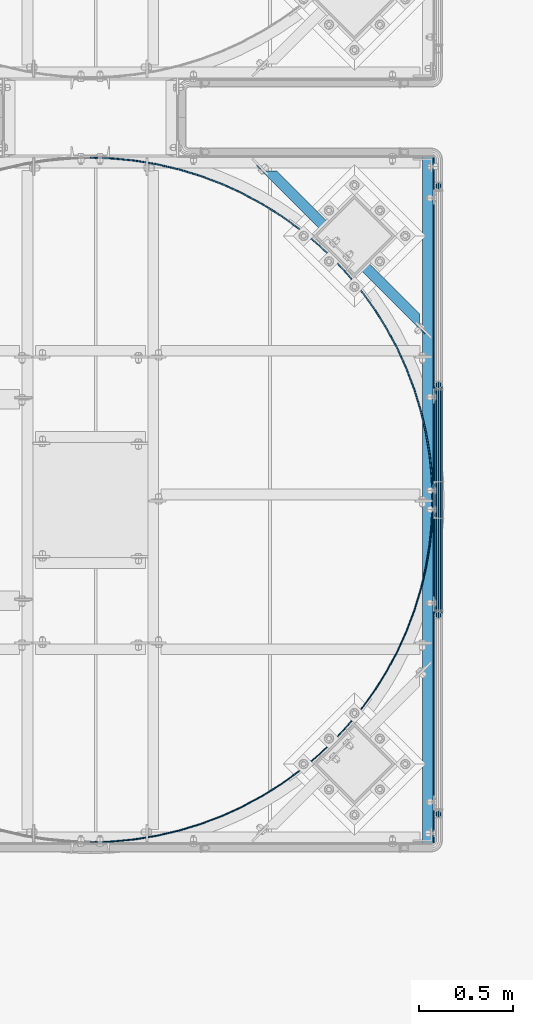
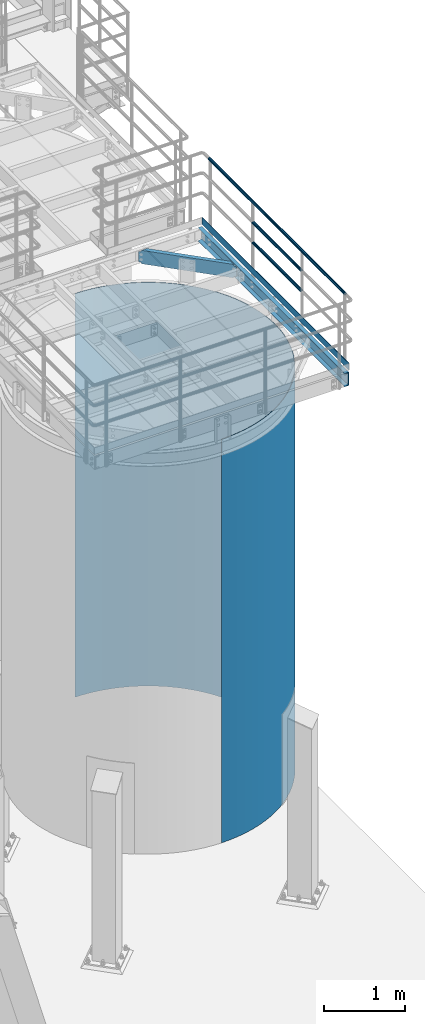
# One storey, part 924 of 1876: 7 beams, 4 elements without a shape of their own.
"""IFC2X3 building model written with IfcOpenShell, lengths in millimetres."""

from ifc_helpers import new_model, si_unit, frame, origin_with_axes, place, context, subcontext, project, spatial, faceted_brep, material, type_object, element, aggregate, save


model = new_model("IFC2X3")

# Units and contexts
model_context = context("Model", 3, precision=1e-05, world=origin_with_axes())
body_context = subcontext(model_context, "Body", "Model", "MODEL_VIEW")
ifc_project = project(units=[si_unit("LENGTHUNIT", "METRE", prefix="MILLI"), si_unit("AREAUNIT", "SQUARE_METRE"), si_unit("VOLUMEUNIT", "CUBIC_METRE"), si_unit("MASSUNIT", "GRAM", prefix="KILO"), si_unit("TIMEUNIT", "SECOND"), si_unit("PLANEANGLEUNIT", "RADIAN"), si_unit("SOLIDANGLEUNIT", "STERADIAN"), si_unit("THERMODYNAMICTEMPERATUREUNIT", "DEGREE_CELSIUS"), si_unit("LUMINOUSINTENSITYUNIT", "LUMEN")], contexts=[model_context])

# Site, building, storey
site_placement = place(None, origin_with_axes())
site = spatial("IfcSite", under=ifc_project, at=site_placement, CompositionType="ELEMENT")
building_placement = place(site_placement, origin_with_axes())
building = spatial("IfcBuilding", under=site, at=building_placement, Name="Undefined", CompositionType="ELEMENT")
storey_placement = place(building_placement, origin_with_axes())
storey = spatial("IfcBuildingStorey", under=building, at=storey_placement, Name="Undefined", CompositionType="ELEMENT", Elevation=0.0)

# Assembly, beams
assembly_1_placement = place(storey_placement, origin_with_axes())
assembly_1 = element("IfcElementAssembly", 1, at=assembly_1_placement, inside=storey, Name="HANDRAIL", AssemblyPlace="NOTDEFINED", PredefinedType="RIGID_FRAME")
ifc_material_1 = material()
beam_type_1 = type_object("IfcBeamType", Name="PIPE1-1/4STD", PredefinedType="NOTDEFINED")
beam_1_placement = place(assembly_1_placement, frame((7025.13056849878, -14198.5644042969, 8480.425), z_axis=(0.0, 0.0, 1.0), x_axis=(0.0, 1.0, 0.0)))
beam_1 = element("IfcBeam", 2, at=beam_1_placement, type_object=beam_type_1, material=ifc_material_1, Name="RAIL", ObjectType="PIPE1-1/4STD", context=body_context, shape_type="Brep", body=[
    faceted_brep([(1200.94245243742, -10.5409999999993, 18.2575475625836), (1200.94245243742, -10.5409999999993, 13.3999612267253), (1200.46603877327, -8.76300000000083, 15.1779612267255), (1198.118, 0.0, 17.5259999999998), (1198.118, 0.0, 21.0820000000003), (1200.46603877327, 8.76300000000083, 15.1779612267255), (1200.94245243742, 10.5409999999993, 13.3999612267253), (1200.94245243742, 10.5409999999993, 18.2575475625836), (1219.2, 21.0820000000003, 0.0), (1208.659, 18.2575475625836, 10.5409999999993), (1208.659, 18.2575475625836, -10.5409999999993), (1205.57941366414, 15.1779612267255, 8.76300000000083), (1207.92745243742, 17.5259999999998, 0.0), (1205.57941366414, 15.1779612267255, -8.76300000000083), (1200.94245243742, 10.5409999999993, -13.3999612267253), (1200.94245243742, 10.5409999999993, -18.2575475625836), (1200.46603877327, 8.76300000000083, -15.1779612267255), (1198.118, 0.0, -17.5259999999998), (1198.118, 0.0, -21.0820000000003), (1200.94245243742, -10.5409999999993, -13.3999612267253), (1200.94245243742, -10.5409999999993, -18.2575475625836), (1200.46603877327, -8.76300000000083, -15.1779612267255), (1219.2, -21.0820000000003, 0.0), (1208.659, -18.2575475625836, -10.5409999999993), (1208.659, -18.2575475625836, 10.5409999999993), (1205.57941366414, -15.1779612267255, -8.76300000000083), (1207.92745243742, -17.5259999999998, 0.0), (1205.57941366414, -15.1779612267255, 8.76300000000083), (10.5409999957128, -18.2575475672238, -10.5409999999993), (18.2575475625817, -10.5410000000011, -18.2575475625836), (9.09494701772928e-13, 21.0820000000003, 0.0), (10.5409999957128, 18.2575475579433, -10.5409999999993), (10.5409999999983, 18.2575475625836, 10.5410000000011), (18.2575475625817, 10.5409999999993, 18.2575475625836), (21.0819999999985, 1.81898940354586e-12, 21.0820000000003), (18.2575475625817, 10.5409999999993, -18.2575475625836), (21.0819999999985, 0.0, -21.0819999999985), (21.0819999999985, 0.0, -17.5259999999998), (18.2575475625817, -10.5409999999974, -13.3999612267271), (18.7339612267233, -8.76300000000083, -15.1779612267255), (18.7339612267251, 8.76299999999901, -15.1779612267255), (18.2575475625817, 10.5410000000011, -13.3999612267235), (13.6205863358573, 15.1779612267255, -8.76299999999901), (11.2725475625839, 17.5259999999998, 0.0), (13.6205863358573, 15.1779612267255, 8.76300000000083), (18.2575475625817, 10.5410000000011, 13.3999612267253), (18.7339612267251, 8.76299999999901, 15.1779612267273), (21.0819999999985, 1.81898940354586e-12, 17.5259999999998), (18.7339612267233, -8.76300000000083, 15.1779612267273), (18.2575475625817, -10.5409999999974, 13.3999612267289), (18.2575475625817, -10.5410000000011, 18.2575475625836), (10.5409999999983, -18.2575475625836, 10.5410000000011), (9.09494701772928e-13, -21.0820000000003, 0.0), (13.6205863358537, -15.1779612267255, 8.76300000000083), (11.2725475625793, -17.5259999999998, 0.0), (13.6205863358537, -15.1779612267255, -8.76299999999901)], [[[0, 1, 2, 3, 4]], [[4, 3, 5, 6, 7]], [[8, 9, 10]], [[7, 6, 11, 12, 13, 14, 15, 10, 9]], [[16, 17, 18, 15, 14]], [[19, 20, 18, 17, 21]], [[22, 23, 24]], [[24, 23, 20, 19, 25, 26, 27, 1, 0]], [[28, 29, 20, 23]], [[30, 31, 32]], [[33, 34, 4, 7]], [[32, 33, 7, 9]], [[30, 32, 9, 8]], [[31, 30, 8, 10]], [[35, 31, 10, 15]], [[36, 35, 15, 18]], [[29, 36, 18, 20]], [[37, 36, 29, 38, 39]], [[40, 41, 35, 36, 37]], [[32, 31, 35, 41, 42, 43, 44, 45, 33]], [[33, 45, 46, 47, 34]], [[34, 47, 48, 49, 50]], [[34, 50, 0, 4]], [[50, 51, 24, 0]], [[51, 52, 22, 24]], [[52, 28, 23, 22]], [[51, 28, 52]], [[50, 49, 53, 54, 55, 38, 29, 28, 51]], [[55, 54, 26, 25]], [[21, 39, 38, 55, 25, 19]], [[37, 39, 21, 17]], [[40, 37, 17, 16]], [[42, 41, 40, 16, 14, 13]], [[43, 42, 13, 12]], [[44, 43, 12, 11]], [[5, 46, 45, 44, 11, 6]], [[47, 46, 5, 3]], [[48, 47, 3, 2]], [[53, 49, 48, 2, 1, 27]], [[54, 53, 27, 26]]]),
])
beam_2_placement = place(assembly_1_placement, frame((7025.13056849878, -12979.3644042969, 8785.225), z_axis=(0.0, 0.0, -1.0), x_axis=(0.0, -1.0, 0.0)))
beam_2 = element("IfcBeam", 3, at=beam_2_placement, type_object=beam_type_1, material=ifc_material_1, Name="RAIL", ObjectType="PIPE1-1/4STD", context=body_context, shape_type="Brep", body=[
    faceted_brep([(9.09494701772928e-13, 21.0820000000003, 0.0), (10.5409999957128, 18.2575475579433, -10.5409999999993), (10.5409999999983, 18.2575475625836, 10.5410000000011), (10.5409999999983, -18.2575475625836, 10.5410000000011), (10.5409999957128, -18.2575475672238, -10.5409999999993), (9.09494701772928e-13, -21.0820000000003, 0.0), (18.2575475625817, -10.5410000000011, 18.2575475625836), (18.2575475625817, -10.5409999999974, 13.3999612267289), (13.6205863358537, -15.1779612267255, 8.76300000000083), (11.2725475625793, -17.5259999999998, 0.0), (13.6205863358537, -15.1779612267255, -8.76299999999901), (18.2575475625817, -10.5409999999974, -13.3999612267271), (18.2575475625817, -10.5410000000011, -18.2575475625836), (21.0819999999985, 0.0, -17.5259999999998), (21.0819999999985, 0.0, -21.0819999999985), (18.7339612267233, -8.76300000000083, -15.1779612267255), (18.7339612267251, 8.76299999999901, -15.1779612267255), (18.2575475625817, 10.5410000000011, -13.3999612267235), (18.2575475625817, 10.5409999999993, -18.2575475625836), (13.6205863358573, 15.1779612267255, -8.76299999999901), (11.2725475625839, 17.5259999999998, 0.0), (13.6205863358573, 15.1779612267255, 8.76300000000083), (18.2575475625817, 10.5410000000011, 13.3999612267253), (18.2575475625817, 10.5409999999993, 18.2575475625836), (18.7339612267251, 8.76299999999901, 15.1779612267273), (21.0819999999985, 1.81898940354586e-12, 17.5259999999998), (21.0819999999985, 1.81898940354586e-12, 21.0820000000003), (18.7339612267233, -8.76300000000083, 15.1779612267273), (1219.2, 21.0820000000003, 0.0), (1208.659, 18.2575475625836, -10.5409999999993), (1200.94245243742, 10.5409999999993, -18.2575475625836), (1219.2, -21.0820000000003, 0.0), (1208.659, -18.2575475625836, -10.5409999999993), (1208.659, -18.2575475625836, 10.5409999999993), (1200.94245243742, -10.5409999999993, 18.2575475625836), (1200.94245243742, -10.5409999999993, -18.2575475625836), (1198.118, 0.0, -21.0820000000003), (1200.46603877327, 8.76300000000083, -15.1779612267255), (1198.118, 0.0, -17.5259999999998), (1200.94245243742, 10.5409999999993, -13.3999612267253), (1200.94245243742, -10.5409999999993, -13.3999612267253), (1200.46603877327, -8.76300000000083, -15.1779612267255), (1205.57941366414, -15.1779612267255, -8.76300000000083), (1207.92745243742, -17.5259999999998, 0.0), (1205.57941366414, -15.1779612267255, 8.76300000000083), (1200.94245243742, -10.5409999999993, 13.3999612267253), (1200.46603877327, -8.76300000000083, 15.1779612267255), (1198.118, 0.0, 17.5259999999998), (1198.118, 0.0, 21.0820000000003), (1200.94245243742, 10.5409999999993, 18.2575475625836), (1208.659, 18.2575475625836, 10.5409999999993), (1200.94245243742, 10.5409999999993, 13.3999612267253), (1205.57941366414, 15.1779612267255, 8.76300000000083), (1207.92745243742, 17.5259999999998, 0.0), (1205.57941366414, 15.1779612267255, -8.76300000000083), (1200.46603877327, 8.76300000000083, 15.1779612267255)], [[[0, 1, 2]], [[3, 4, 5]], [[6, 7, 8, 9, 10, 11, 12, 4, 3]], [[13, 14, 12, 11, 15]], [[16, 17, 18, 14, 13]], [[2, 1, 18, 17, 19, 20, 21, 22, 23]], [[23, 22, 24, 25, 26]], [[26, 25, 27, 7, 6]], [[1, 0, 28, 29]], [[18, 1, 29, 30]], [[31, 32, 33]], [[6, 3, 33, 34]], [[3, 5, 31, 33]], [[5, 4, 32, 31]], [[4, 12, 35, 32]], [[12, 14, 36, 35]], [[14, 18, 30, 36]], [[37, 38, 36, 30, 39]], [[40, 35, 36, 38, 41]], [[33, 32, 35, 40, 42, 43, 44, 45, 34]], [[34, 45, 46, 47, 48]], [[26, 6, 34, 48]], [[2, 23, 49, 50]], [[23, 26, 48, 49]], [[0, 2, 50, 28]], [[28, 50, 29]], [[49, 51, 52, 53, 54, 39, 30, 29, 50]], [[48, 47, 55, 51, 49]], [[25, 24, 55, 47]], [[55, 24, 22, 21, 52, 51]], [[21, 20, 53, 52]], [[20, 19, 54, 53]], [[19, 17, 16, 37, 39, 54]], [[16, 13, 38, 37]], [[13, 15, 41, 38]], [[41, 15, 11, 10, 42, 40]], [[10, 9, 43, 42]], [[9, 8, 44, 43]], [[8, 7, 27, 46, 45, 44]], [[27, 25, 47, 46]]]),
])
beam_3_placement = place(assembly_1_placement, frame((7025.13056849878, -11904.1824042969, 9090.025), z_axis=(0.0, 0.0, -1.0), x_axis=(0.0, -1.0, 0.0)))
beam_3 = element("IfcBeam", 4, at=beam_3_placement, type_object=beam_type_1, material=ifc_material_1, Name="HANDRAIL", ObjectType="PIPE1-1/4STD", context=body_context, shape_type="Brep", body=[
    faceted_brep([(0.0, -17.5259999999998, 0.0), (0.0, -15.1779612267264, 8.76300000000083), (3369.564, -15.177961226726, 8.76300000000083), (3369.564, -17.5259999999998, 0.0), (0.0, -8.76299999999992, 15.1779612267255), (3369.564, -8.76299999999992, 15.1779612267255), (0.0, 0.0, 17.5259999999998), (3369.564, 0.0, 17.5259999999998), (0.0, 8.76299999999992, 15.1779612267255), (3369.564, 8.76299999999992, 15.1779612267255), (0.0, 15.1779612267264, 8.76300000000083), (3369.564, 15.177961226726, 8.76300000000083), (0.0, 17.5259999999998, 0.0), (3369.564, 17.5259999999998, 0.0), (0.0, 15.1779612267264, -8.76300000000083), (3369.564, 15.177961226726, -8.76300000000083), (0.0, 8.76299999999992, -15.1779612267255), (3369.564, 8.76299999999992, -15.1779612267255), (0.0, 0.0, -17.5259999999998), (3369.564, 0.0, -17.5259999999998), (0.0, -8.76299999999992, -15.1779612267255), (3369.564, -8.76299999999992, -15.1779612267255), (0.0, -15.1779612267264, -8.76300000000083), (3369.564, -15.177961226726, -8.76300000000083), (9.09494701772928e-13, -21.0820000000003, 0.0), (0.0, -18.2575475625836, -10.5409999999993), (3369.564, -18.2575475625836, -10.5409999999993), (3369.564, -21.0819999999999, 0.0), (0.0, -10.5410000000002, -18.2575475625836), (3369.564, -10.5410000000002, -18.2575475625836), (-4.28826751885936e-09, 0.0, -21.0820000000003), (3369.564, 0.0, -21.0820000000003), (0.0, 10.5410000000002, -18.2575475625836), (3369.564, 10.5410000000002, -18.2575475625836), (0.0, 18.2575475625836, -10.5409999999993), (3369.564, 18.2575475625836, -10.5409999999993), (9.09494701772928e-13, 21.0820000000003, 0.0), (3369.564, 21.0819999999999, 0.0), (0.0, 18.2575475625836, 10.5409999999993), (3369.564, 18.2575475625836, 10.5409999999993), (0.0, 10.5410000000002, 18.2575475625836), (3369.564, 10.5410000000002, 18.2575475625836), (0.0, 0.0, 21.0820000000003), (3369.564, 0.0, 21.0820000000003), (0.0, -10.5410000000002, 18.2575475625836), (3369.564, -10.5410000000002, 18.2575475625836), (0.0, -18.2575475625836, 10.5409999999993), (3369.564, -18.2575475625836, 10.5409999999993)], [[[0, 1, 2, 3]], [[1, 4, 5, 2]], [[4, 6, 7, 5]], [[6, 8, 9, 7]], [[8, 10, 11, 9]], [[10, 12, 13, 11]], [[12, 14, 15, 13]], [[14, 16, 17, 15]], [[16, 18, 19, 17]], [[18, 20, 21, 19]], [[20, 22, 23, 21]], [[22, 0, 3, 23]], [[24, 25, 26, 27]], [[25, 28, 29, 26]], [[28, 30, 31, 29]], [[30, 32, 33, 31]], [[32, 34, 35, 33]], [[34, 36, 37, 35]], [[36, 38, 39, 37]], [[38, 40, 41, 39]], [[40, 42, 43, 41]], [[42, 44, 45, 43]], [[44, 46, 47, 45]], [[46, 24, 27, 47]], [[29, 31, 33, 35, 37, 39, 41, 43, 45, 47, 27, 26], [5, 7, 9, 11, 13, 15, 17, 19, 21, 23, 3, 2]], [[46, 44, 42, 40, 38, 36, 34, 32, 30, 28, 25, 24], [22, 20, 18, 16, 14, 12, 10, 8, 6, 4, 1, 0]]]),
])
ifc_material_2 = material(Name="STEEL/A36")
beam_type_2 = type_object("IfcBeamType", PredefinedType="NOTDEFINED")
beam_4_placement = place(assembly_1_placement, frame((7000.87356849878, -15405.0644042969, 8080.375), z_axis=(0.0, 0.0, 1.0), x_axis=(0.0, 1.0, 0.0)))
beam_4 = element("IfcBeam", 5, at=beam_4_placement, type_object=beam_type_2, material=ifc_material_2, Name="PLATE", context=body_context, shape_type="Brep", body=[
    faceted_brep([(0.0, 3.17500000000018, -50.8000000000002), (0.0, 3.17500000000018, 50.8000000000002), (3632.1999511731, 3.17500000000018, 50.8000000000002), (3632.1999511731, 3.17500000000018, -50.8000000000002), (0.0, -3.17500000000018, 50.8000000000002), (3632.1999511731, -3.17500000000018, 50.8000000000002), (0.0, -3.17500000000018, -50.8000000000002), (3632.1999511731, -3.17500000000018, -50.8000000000002)], [[[0, 1, 2, 3]], [[1, 4, 5, 2]], [[4, 6, 7, 5]], [[6, 0, 3, 7]], [[5, 7, 3, 2]], [[6, 4, 1, 0]]]),
])
aggregate(assembly_1, [beam_4, beam_1, beam_2, beam_3])

# Assembly, beam
assembly_2_placement = place(storey_placement, origin_with_axes())
assembly_2 = element("IfcElementAssembly", 6, at=assembly_2_placement, inside=storey, Name="BEAM", AssemblyPlace="NOTDEFINED", PredefinedType="RIGID_FRAME")
beam_type_3 = type_object("IfcBeamType", Name="C8X11.5", PredefinedType="NOTDEFINED")
beam_5_placement = place(assembly_2_placement, frame((6039.01195777119, -11756.6276268513, 7896.225), z_axis=(0.0, 0.0, -1.0), x_axis=(0.707106781186547, -0.707106781186548, 0.0)))
beam_5 = element("IfcBeam", 7, at=beam_5_placement, type_object=beam_type_3, material=ifc_material_2, Name="BEAM", ObjectType="C8X11.5", context=body_context, shape_type="Brep", body=[
    faceted_brep([(1223.93966372519, -28.5750000000044, 101.6), (1281.0896637252, 28.5750000000053, 101.6), (97.6602831589025, 28.5750000000062, 101.6), (154.810283158913, -28.5750000000035, 101.6), (1223.93966372519, -28.5750000000044, 96.8355949999996), (154.810283158913, -28.5750000000035, 96.8355949999996), (1271.57228791927, 19.0576241940789, 88.8999998092668), (1281.0896637252, 28.5750000000053, 88.8999998092668), (1223.93966372655, -28.5750000000035, -101.6), (1223.93966372655, -28.5750000000035, -96.8355949999996), (154.81028315886, -28.5750000000044, -96.8355949999996), (154.81028315886, -28.5750000000044, -101.6), (1271.57228792066, 19.0576241941089, -88.8999998092622), (1274.88810387369, 22.225000000004, -88.3723149999996), (103.861843011711, 22.225000000004, -88.3723149999996), (107.177658964769, 19.0576241940862, -88.8999998092659), (86.0497711864464, 22.225000000004, -76.2000000000007), (79.6997711864442, 28.5750000000053, -76.2000000000007), (86.572961555079, 28.5750000000053, -77.1667299225883), (92.9229615550812, 22.225000000004, -77.1667299225883), (92.3997709957148, 28.5750000000053, -79.9197438230667), (98.7497709957152, 22.225000000004, -79.9197438230667), (96.2931205911736, 28.5750000000053, -84.0399202912204), (102.643120591174, 22.2250000000049, -84.0399202912204), (97.6602831588498, 28.5750000000053, -88.8999998092659), (97.6602831588498, 28.5750000000053, -101.6), (1281.08966372656, 28.5750000000062, -101.6), (1281.08966372656, 28.5750000000062, -88.8999998092622), (1282.45682629424, 28.5750000000044, -84.0399202912167), (1276.10682629423, 22.2250000000031, -84.0399202912167), (1286.35017588969, 28.5750000000062, -79.9197438230631), (1280.00017588969, 22.2250000000049, -79.9197438230631), (1292.17698533033, 28.5750000000062, -77.1667299225846), (1285.82698533033, 22.2250000000049, -77.1667299225846), (1299.05017569896, 28.5750000000053, -76.1999999999971), (1292.70017569896, 22.225000000004, -76.1999999999971), (1319.3218385947, 28.5750000000053, -76.1999999999971), (1319.3218385947, 22.225000000004, -76.1999999999971), (1319.3218385947, 28.5750000000053, 76.2000000000016), (1319.3218385947, 22.225000000004, 76.2000000000016), (1299.0501756976, 28.5750000000053, 76.2000000000016), (1292.7001756976, 22.2250000000049, 76.2000000000016), (1292.17698532897, 28.5750000000053, 77.1667299225892), (1285.82698532897, 22.225000000004, 77.1667299225892), (1286.35017588834, 28.5750000000053, 79.9197438230676), (1280.00017588834, 22.225000000004, 79.9197438230676), (1282.45682629288, 28.5750000000044, 84.0399202912213), (1276.10682629288, 22.225000000004, 84.0399202912213), (1274.88810387234, 22.2250000000049, 88.3723149999996), (103.861843011768, 22.2250000000049, 88.3723149999996), (107.177658964813, 19.0576241940971, 88.899999809264), (97.6602831589025, 28.5750000000062, 88.899999809264), (96.2931205912264, 28.5750000000053, 84.0399202912186), (102.643120591229, 22.225000000004, 84.0399202912186), (92.3997709957694, 28.5750000000053, 79.9197438230649), (98.7497709957697, 22.2250000000049, 79.9197438230649), (86.5729615551336, 28.5750000000062, 77.1667299225865), (92.922961555134, 22.2250000000049, 77.1667299225865), (79.6997711864988, 28.5750000000053, 76.1999999999989), (86.0497711865009, 22.225000000004, 76.1999999999989), (59.4281082869256, 22.225000000004, 76.1999999999989), (59.4281082869256, 22.225000000004, -76.2000000000007), (59.4281082869256, 28.5750000000062, -76.2000000000007), (59.4281082869256, 28.5750000000062, 76.1999999999989)], [[[0, 1, 2, 3]], [[4, 0, 3, 5]], [[1, 0, 4, 6, 7]], [[8, 9, 10, 11]], [[9, 12, 13, 14, 15, 10]], [[16, 17, 18, 19]], [[19, 18, 20, 21]], [[21, 20, 22, 23]], [[14, 23, 22, 24, 15]], [[10, 15, 24, 25, 11]], [[26, 8, 11, 25]], [[27, 12, 9, 8, 26]], [[28, 29, 13, 12, 27]], [[30, 31, 29, 28]], [[32, 33, 31, 30]], [[34, 35, 33, 32]], [[35, 34, 36, 37]], [[36, 38, 39, 37]], [[40, 41, 39, 38]], [[42, 43, 41, 40]], [[44, 45, 43, 42]], [[46, 47, 45, 44]], [[7, 6, 48, 47, 46]], [[49, 48, 6, 4, 5, 50]], [[3, 2, 51, 50, 5]], [[50, 51, 52, 53, 49]], [[53, 52, 54, 55]], [[55, 54, 56, 57]], [[57, 56, 58, 59]], [[16, 19, 21, 23, 14, 13, 29, 31, 33, 35, 37, 39, 41, 43, 45, 47, 48, 49, 53, 55, 57, 59, 60, 61]], [[17, 16, 61, 62]], [[58, 56, 54, 52, 51, 2, 1, 7, 46, 44, 42, 40, 38, 36, 34, 32, 30, 28, 27, 26, 25, 24, 22, 20, 18, 17, 62, 63]], [[59, 58, 63, 60]], [[62, 61, 60, 63]]]),
])
aggregate(assembly_2, [beam_5])

assembly_3_placement = place(storey_placement, origin_with_axes())
assembly_3 = element("IfcElementAssembly", 8, at=assembly_3_placement, inside=storey, Name="BEAM", AssemblyPlace="NOTDEFINED", PredefinedType="RIGID_FRAME")
beam_6_placement = place(assembly_3_placement, frame((6969.12356849878, -15405.0644042969, 7896.225), z_axis=(0.0, 0.0, -1.0), x_axis=(0.0, 1.0, 0.0)))
beam_6 = element("IfcBeam", 9, at=beam_6_placement, type_object=beam_type_3, material=ifc_material_2, Name="BEAM", ObjectType="C8X11.5", context=body_context, shape_type="Brep", body=[
    faceted_brep([(0.0, 28.5749999999998, -101.6), (0.0, 28.5749999999998, 101.6), (3632.1999511731, 28.5749999999998, 101.6), (3632.1999511731, 28.5749999999998, -101.6), (0.0, -28.5749999999998, 101.6), (3632.1999511731, -28.5749999999998, 101.6), (0.0, -28.5749999999998, 96.8355950000005), (3632.1999511731, -28.5749999999998, 96.8355949999996), (0.0, 22.2250000000004, 88.3723150000005), (3632.1999511731, 22.2250000000004, 88.3723149999996), (0.0, 22.2250000000004, -88.3723150000005), (3632.1999511731, 22.2250000000004, -88.3723149999996), (0.0, -28.5749999999998, -96.8355950000005), (3632.1999511731, -28.5749999999998, -96.8355949999996), (0.0, -28.5749999999998, -101.6), (3632.1999511731, -28.5749999999998, -101.6)], [[[0, 1, 2, 3]], [[1, 4, 5, 2]], [[4, 6, 7, 5]], [[6, 8, 9, 7]], [[8, 10, 11, 9]], [[10, 12, 13, 11]], [[12, 14, 15, 13]], [[14, 0, 3, 15]], [[5, 7, 9, 11, 13, 15, 3, 2]], [[14, 12, 10, 8, 6, 4, 1, 0]]]),
])
aggregate(assembly_3, [beam_6])

assembly_4_placement = place(storey_placement, origin_with_axes())
assembly_4 = element("IfcElementAssembly", 10, at=assembly_4_placement, inside=storey, Name="PLATE", AssemblyPlace="NOTDEFINED", PredefinedType="RIGID_FRAME")
beam_type_4 = type_object("IfcBeamType", PredefinedType="NOTDEFINED")
beam_7_placement = place(assembly_4_placement, frame((5179.35352888198, -15402.8193402666, 4572.0), z_axis=(0.0, 0.0, 1.0), x_axis=(0.707106781186548, 0.707106781186547, 0.0)))
beam_7 = element("IfcBeam", 11, at=beam_7_placement, type_object=beam_type_4, material=ifc_material_2, Name="PLATE", context=body_context, shape_type="Brep", body=[
    faceted_brep([(-9.09494701772928e-13, -3.17500000000109, -3048.0), (-9.09494701772928e-13, -3.17500000000109, 3048.0), (4.49012806053361, 1.31512806053615, 3048.0), (4.49012806053361, 1.31512806053615, -3048.0), (90.9255352695482, -79.640465180064, 3048.0), (90.9255352695482, -79.640465180064, -3048.0), (86.7386893436624, -84.4146479575556, -3048.0), (86.7386893436624, -84.4146479575556, 3048.0), (178.604991689236, -159.807373884372, -3048.0), (178.604991689236, -159.807373884372, 3048.0), (182.47062676344, -154.769580173521, 3048.0), (182.47062676344, -154.769580173521, -3048.0), (275.205521426504, -229.030334553527, -3048.0), (275.205521426504, -229.030334553527, 3048.0), (278.733392406178, -223.750502515404, 3048.0), (278.733392406177, -223.750502515404, -3048.0), (376.126620256749, -291.787106620137, -3048.0), (376.126620256749, -291.787106620137, 3048.0), (379.301620256748, -286.287845306104, 3048.0), (379.301620256748, -286.287845306104, -3048.0), (480.936128541091, -347.808955951614, -3048.0), (480.936128541091, -347.808955951614, 3048.0), (483.744661723981, -342.113814042879, 3048.0), (483.744661723981, -342.113814042879, -3048.0), (589.185235874409, -396.85598838849, -3048.0), (589.185235874409, -396.85598838849, 3048.0), (591.615275669926, -390.989353357043, 3048.0), (591.615275669926, -390.989353357043, -3048.0), (700.410402960397, -438.718177008037, -3048.0), (700.410402960397, -438.718177008037, 3048.0), (702.45154356507, -432.70517068574, 3048.0), (702.45154356507, -432.70517068574, -3048.0), (814.135346557992, -473.216261491782, -3048.0), (814.135346557992, -473.216261491782, 3048.0), (815.778847494393, -467.082632494845, 3048.0), (815.778847494393, -467.082632494845, -3048.0), (929.873078999343, -500.202515745726, -3048.0), (929.873078999343, -500.202515745726, 3048.0), (931.111902544145, -493.974529215166, 3048.0), (931.111902544145, -493.974529215166, -3048.0), (1047.12799354576, -519.561380486148, -3048.0), (1047.12799354576, -519.561380486148, 3048.0), (1047.95683486635, -513.265705616424, 3048.0), (1047.95683486635, -513.265705616424, -3048.0), (1165.39798665184, -531.209958082203, -3048.0), (1165.39798665184, -531.209958082203, 3048.0), (1165.81329652245, -524.873553919637, 3048.0), (1165.81329652245, -524.873553919637, -3048.0), (1284.17660804997, -535.098367536304, -3048.0), (1284.17660804997, -535.098367536304, 3048.0), (1284.17660804997, -528.748367536302, 3048.0), (1284.17660804997, -528.748367536302, -3048.0), (1402.95522944811, -531.209958082205, -3048.0), (1402.95522944811, -531.209958082205, 3048.0), (1402.5399195775, -524.873553919639, 3048.0), (1402.5399195775, -524.873553919639, -3048.0), (1521.22522255419, -519.56138048615, -3048.0), (1521.22522255419, -519.56138048615, 3048.0), (1520.39638123359, -513.265705616424, 3048.0), (1520.39638123359, -513.265705616424, -3048.0), (1638.4801371006, -500.202515745726, -3048.0), (1638.4801371006, -500.202515745726, 3048.0), (1637.2413135558, -493.974529215166, 3048.0), (1637.2413135558, -493.974529215166, -3048.0), (1754.21786954195, -473.216261491782, -3048.0), (1754.21786954195, -473.216261491782, 3048.0), (1752.57436860555, -467.082632494845, 3048.0), (1752.57436860555, -467.082632494845, -3048.0), (1867.94281313955, -438.718177008037, -3048.0), (1867.94281313955, -438.718177008037, 3048.0), (1865.90167253487, -432.705170685742, 3048.0), (1865.90167253487, -432.705170685742, -3048.0), (1979.16798022554, -396.85598838849, -3048.0), (1979.16798022554, -396.85598838849, 3048.0), (1976.73794043002, -390.989353357041, 3048.0), (1976.73794043002, -390.989353357041, -3048.0), (2087.41708755885, -347.808955951614, -3048.0), (2087.41708755885, -347.808955951614, 3048.0), (2084.60855437596, -342.113814042879, 3048.0), (2084.60855437596, -342.113814042879, -3048.0), (2192.2265958432, -291.787106620137, -3048.0), (2192.2265958432, -291.787106620137, 3048.0), (2189.0515958432, -286.287845306104, 3048.0), (2189.0515958432, -286.287845306104, -3048.0), (2293.14769467344, -229.030334553529, -3048.0), (2293.14769467344, -229.030334553529, 3048.0), (2289.61982369377, -223.750502515408, 3048.0), (2289.61982369377, -223.750502515408, -3048.0), (2389.74822441071, -159.807373884372, -3048.0), (2389.74822441071, -159.807373884372, 3048.0), (2385.8825893365, -154.769580173523, 3048.0), (2385.8825893365, -154.769580173523, -3048.0), (2481.61452675628, -84.4146479575593, -3048.0), (2481.61452675628, -84.4146479575593, 3048.0), (2477.4276808304, -79.640465180064, 3048.0), (2477.4276808304, -79.640465180064, -3048.0), (2568.35321609995, -3.17500000000109, -3048.0), (2568.35321609995, -3.17500000000109, 3048.0), (2563.86308803941, 1.31512806053615, 3048.0), (2563.86308803941, 1.31512806053615, -3048.0), (2724.98558998438, 175.429991689211, 3048.0), (2794.20855065356, 272.030521426468, 3048.0), (2856.9653227202, 372.951620256708, 3048.0), (2912.9871720517, 477.761128541046, 3048.0), (2962.0342044886, 586.010235874362, 3048.0), (3003.89639310817, 697.235402960352, 3048.0), (3038.39447759193, 810.960346557951, 3048.0), (3065.38073184589, 926.698078999309, 3048.0), (3084.73959658633, 1043.95299354573, 3048.0), (3096.3881741824, 1162.22298665182, 3048.0), (3100.27658363651, 1281.00160804996, 3048.0), (3096.38817418241, 1399.78022944811, 3048.0), (3084.73959658636, 1518.0502225542, 3048.0), (3065.38073184594, 1635.30513710062, 3048.0), (3038.394477592, 1751.04286954198, 3048.0), (3003.89639310825, 1864.76781313958, 3048.0), (2962.0342044887, 1975.99298022558, 3048.0), (2912.98717205181, 2084.2420875589, 3048.0), (2856.96532272032, 2189.05159584325, 3048.0), (2794.2085506537, 2289.9726946735, 3048.0), (2724.98558998453, 2386.57322441077, 3048.0), (2649.5928640577, 2478.43952675634, 3048.0), (2568.35321610013, 2565.1782161, 3048.0), (2563.86308803959, 2560.68808803946, 3048.0), (2644.8186812802, 2474.25268083045, 3048.0), (2719.94779627368, 2382.70758933656, 3048.0), (2788.92871861558, 2286.44482369382, 3048.0), (2851.46606140629, 2185.87659584325, 3048.0), (2907.29203014307, 2081.43355437601, 3048.0), (2956.16756945725, 1973.56294043006, 3048.0), (2997.88338678595, 1862.72667253491, 3048.0), (3032.26084859506, 1749.39936860558, 3048.0), (3059.15274531538, 1634.06631355582, 3048.0), (3078.44392171664, 1517.2213812336, 3048.0), (3090.05177001985, 1399.36491957749, 3048.0), (3093.9265836365, 1281.00160804996, 3048.0), (3090.05177001983, 1162.63829652243, 3048.0), (3078.4439217166, 1044.78183486632, 3048.0), (3059.15274531533, 927.93690254411, 3048.0), (3032.26084859499, 812.603847494354, 3048.0), (2997.88338678587, 699.276543565027, 3048.0), (2956.16756945715, 588.440275669882, 3048.0), (2907.29203014296, 480.569661723937, 3048.0), (2851.46606140616, 376.126620256708, 3048.0), (2788.92871861544, 275.558392406143, 3048.0), (2719.94779627353, 179.295626763416, 3048.0), (2644.81868128004, 87.7505352695352, 3048.0), (2649.59286405753, 83.5636893436476, 3048.0), (2644.81868128004, 87.7505352695352, -3048.0), (2719.94779627353, 179.295626763416, -3048.0), (2788.92871861544, 275.558392406143, -3048.0), (2851.46606140616, 376.126620256708, -3048.0), (2907.29203014296, 480.569661723937, -3048.0), (2956.16756945715, 588.440275669882, -3048.0), (2997.88338678587, 699.276543565027, -3048.0), (3032.26084859499, 812.603847494354, -3048.0), (3059.15274531533, 927.93690254411, -3048.0), (3078.4439217166, 1044.78183486632, -3048.0), (3090.05177001983, 1162.63829652243, -3048.0), (3093.9265836365, 1281.00160804996, -3048.0), (3090.05177001985, 1399.36491957749, -3048.0), (3078.44392171664, 1517.2213812336, -3048.0), (3059.15274531538, 1634.06631355582, -3048.0), (3032.26084859506, 1749.39936860558, -3048.0), (2997.88338678595, 1862.72667253491, -3048.0), (2956.16756945725, 1973.56294043006, -3048.0), (2907.29203014307, 2081.43355437601, -3048.0), (2851.46606140629, 2185.87659584325, -3048.0), (2788.92871861558, 2286.44482369382, -3048.0), (2719.94779627368, 2382.70758933656, -3048.0), (2644.8186812802, 2474.25268083045, -3048.0), (2563.86308803959, 2560.68808803946, -3048.0), (2568.35321610013, 2565.1782161, -3048.0), (2649.5928640577, 2478.43952675634, -3048.0), (2724.98558998453, 2386.57322441077, -3048.0), (2794.2085506537, 2289.9726946735, -3048.0), (2856.96532272032, 2189.05159584325, -3048.0), (2912.98717205181, 2084.2420875589, -3048.0), (2962.0342044887, 1975.99298022558, -3048.0), (3003.89639310825, 1864.76781313958, -3048.0), (3038.394477592, 1751.04286954198, -3048.0), (3065.38073184594, 1635.30513710062, -3048.0), (3084.73959658636, 1518.0502225542, -3048.0), (3096.38817418241, 1399.78022944811, -3048.0), (3100.27658363651, 1281.00160804996, -3048.0), (3096.3881741824, 1162.22298665182, -3048.0), (3084.73959658633, 1043.95299354573, -3048.0), (3065.38073184589, 926.698078999309, -3048.0), (3038.39447759193, 810.960346557951, -3048.0), (3003.89639310817, 697.235402960352, -3048.0), (2962.0342044886, 586.010235874362, -3048.0), (2912.9871720517, 477.761128541046, -3048.0), (2856.9653227202, 372.951620256708, -3048.0), (2794.20855065356, 272.030521426468, -3048.0), (2724.98558998438, 175.429991689211, -3048.0), (2649.59286405753, 83.5636893436476, -3048.0)], [[[0, 1, 2, 3]], [[3, 2, 4, 5]], [[1, 0, 6, 7]], [[6, 8, 9, 7]], [[4, 10, 11, 5]], [[8, 12, 13, 9]], [[10, 14, 15, 11]], [[12, 16, 17, 13]], [[14, 18, 19, 15]], [[16, 20, 21, 17]], [[18, 22, 23, 19]], [[20, 24, 25, 21]], [[22, 26, 27, 23]], [[24, 28, 29, 25]], [[26, 30, 31, 27]], [[28, 32, 33, 29]], [[30, 34, 35, 31]], [[32, 36, 37, 33]], [[34, 38, 39, 35]], [[36, 40, 41, 37]], [[38, 42, 43, 39]], [[40, 44, 45, 41]], [[42, 46, 47, 43]], [[44, 48, 49, 45]], [[46, 50, 51, 47]], [[48, 52, 53, 49]], [[50, 54, 55, 51]], [[52, 56, 57, 53]], [[54, 58, 59, 55]], [[56, 60, 61, 57]], [[58, 62, 63, 59]], [[60, 64, 65, 61]], [[62, 66, 67, 63]], [[64, 68, 69, 65]], [[66, 70, 71, 67]], [[68, 72, 73, 69]], [[70, 74, 75, 71]], [[72, 76, 77, 73]], [[74, 78, 79, 75]], [[76, 80, 81, 77]], [[78, 82, 83, 79]], [[80, 84, 85, 81]], [[82, 86, 87, 83]], [[84, 88, 89, 85]], [[86, 90, 91, 87]], [[88, 92, 93, 89]], [[90, 94, 95, 91]], [[92, 96, 97, 93]], [[94, 98, 99, 95]], [[100, 101, 102, 103, 104, 105, 106, 107, 108, 109, 110, 111, 112, 113, 114, 115, 116, 117, 118, 119, 120, 121, 122, 123, 124, 125, 126, 127, 128, 129, 130, 131, 132, 133, 134, 135, 136, 137, 138, 139, 140, 141, 142, 143, 144, 145, 146, 98, 94, 90, 86, 82, 78, 74, 70, 66, 62, 58, 54, 50, 46, 42, 38, 34, 30, 26, 22, 18, 14, 10, 4, 2, 1, 7, 9, 13, 17, 21, 25, 29, 33, 37, 41, 45, 49, 53, 57, 61, 65, 69, 73, 77, 81, 85, 89, 93, 97, 147]], [[99, 98, 146, 148]], [[149, 150, 151, 152, 153, 154, 155, 156, 157, 158, 159, 160, 161, 162, 163, 164, 165, 166, 167, 168, 169, 170, 171, 172, 173, 174, 175, 176, 177, 178, 179, 180, 181, 182, 183, 184, 185, 186, 187, 188, 189, 190, 191, 192, 193, 194, 195, 96, 92, 88, 84, 80, 76, 72, 68, 64, 60, 56, 52, 48, 44, 40, 36, 32, 28, 24, 20, 16, 12, 8, 6, 0, 3, 5, 11, 15, 19, 23, 27, 31, 35, 39, 43, 47, 51, 55, 59, 63, 67, 71, 75, 79, 83, 87, 91, 95, 99, 148]], [[97, 96, 195, 147]], [[195, 194, 100, 147]], [[146, 145, 149, 148]], [[194, 193, 101, 100]], [[145, 144, 150, 149]], [[193, 192, 102, 101]], [[144, 143, 151, 150]], [[192, 191, 103, 102]], [[143, 142, 152, 151]], [[191, 190, 104, 103]], [[142, 141, 153, 152]], [[190, 189, 105, 104]], [[141, 140, 154, 153]], [[189, 188, 106, 105]], [[140, 139, 155, 154]], [[188, 187, 107, 106]], [[139, 138, 156, 155]], [[187, 186, 108, 107]], [[138, 137, 157, 156]], [[186, 185, 109, 108]], [[137, 136, 158, 157]], [[185, 184, 110, 109]], [[136, 135, 159, 158]], [[184, 183, 111, 110]], [[135, 134, 160, 159]], [[183, 182, 112, 111]], [[134, 133, 161, 160]], [[182, 181, 113, 112]], [[133, 132, 162, 161]], [[181, 180, 114, 113]], [[132, 131, 163, 162]], [[180, 179, 115, 114]], [[131, 130, 164, 163]], [[179, 178, 116, 115]], [[130, 129, 165, 164]], [[178, 177, 117, 116]], [[129, 128, 166, 165]], [[177, 176, 118, 117]], [[128, 127, 167, 166]], [[176, 175, 119, 118]], [[127, 126, 168, 167]], [[175, 174, 120, 119]], [[126, 125, 169, 168]], [[174, 173, 121, 120]], [[125, 124, 170, 169]], [[122, 172, 171, 123]], [[173, 172, 122, 121]], [[124, 123, 171, 170]]]),
])
aggregate(assembly_4, [beam_7])

save(model, "model.ifc")
